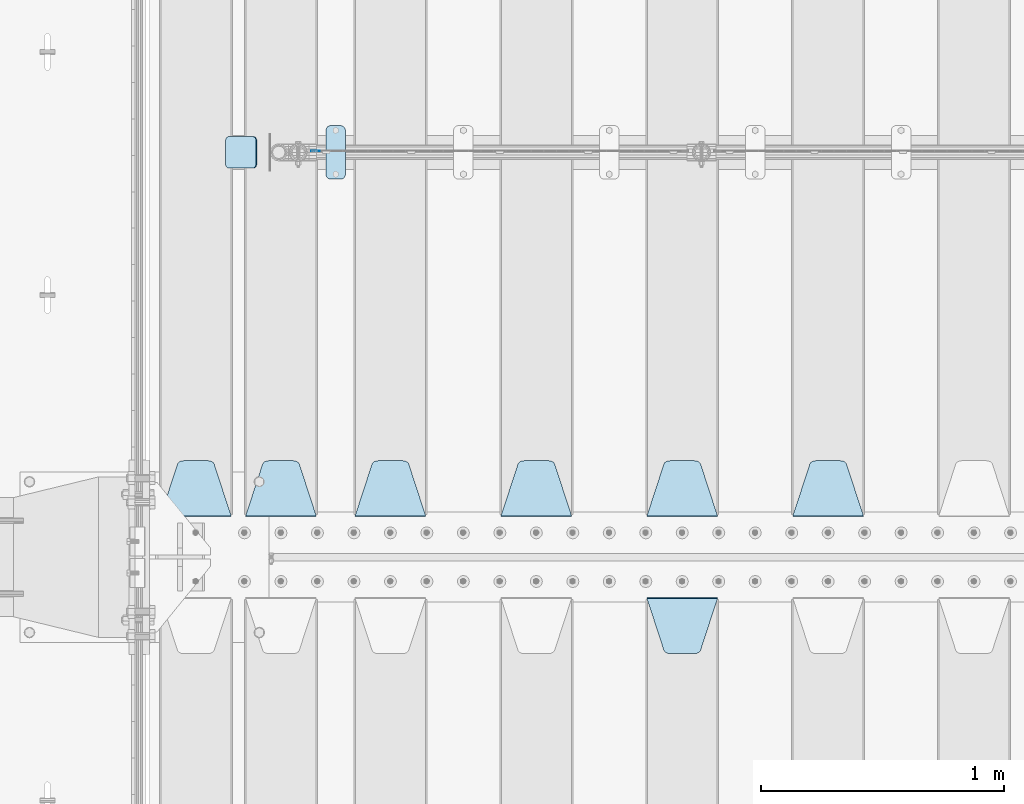
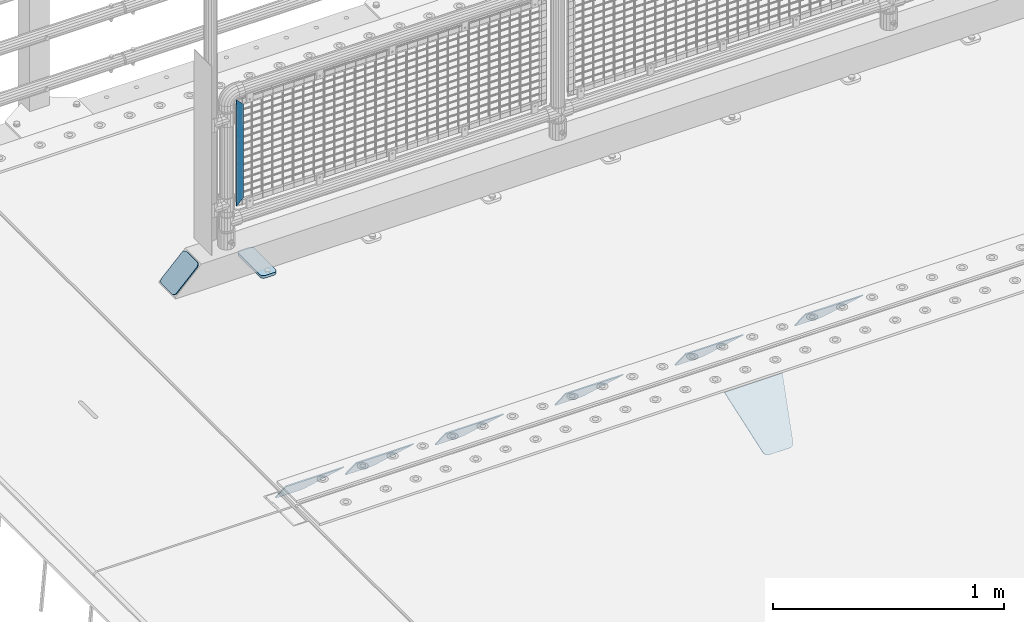
# One storey, part 210 of 240: 10 plates.
"""IFC2X3 building model written with IfcOpenShell, lengths in millimetres."""

import ifcopenshell
import ifcopenshell.guid

model = None  # the IFC model being written
_history = None  # IfcOwnerHistory: only IFC2X3 demands one
_inside = {}  # id of a spatial element -> (the spatial element, [elements in it])
_under = {}  # id of a project, library or spatial element -> (it, [spatial elements below it])
_declared = {}  # id of a project -> (the project, [libraries it declares])
_typed = {}  # id of a type object -> (the type object, [elements of that type])
_made_of = {}  # id of a material, layer set ... -> (it, [elements and type objects made of it])


def new_model(schema):
    """Start an empty IFC model of exactly this schema.

    Asked for "IFC4X3", IfcOpenShell would pick the latest addendum, in which some entities
    have other attributes; the version numbers below select the first issue.
    IFC2X3 requires an IfcOwnerHistory on every rooted entity: one is made here for all.
    """
    global model, _history
    if schema == "IFC4X3":
        model = ifcopenshell.file(schema_version=(4, 3, 0, 0))
    else:
        model = ifcopenshell.file(schema=schema)
    _inside.clear()
    _under.clear()
    _declared.clear()
    _typed.clear()
    _made_of.clear()
    _history = None
    if model.schema == "IFC2X3":
        org = make("IfcOrganization", Name="unknown")
        user = make(
            "IfcPersonAndOrganization",
            ThePerson=make("IfcPerson", FamilyName="unknown"),
            TheOrganization=org,
        )
        app = make(
            "IfcApplication",
            ApplicationDeveloper=org,
            Version="unknown",
            ApplicationFullName="unknown",
            ApplicationIdentifier="unknown",
        )
        _history = make(
            "IfcOwnerHistory",
            OwningUser=user,
            OwningApplication=app,
            ChangeAction="ADDED",
            CreationDate=0,
        )
    return model


def make(cls, **values):
    """One entity of the class cls with the attributes given. An attribute that is None is left unset."""
    return model.create_entity(
        cls, **{name: value for name, value in values.items() if value is not None}
    )


def rooted(cls, **values):
    """An entity with a GlobalId (a new one), such as an element, a storey or a relation."""
    return make(cls, GlobalId=ifcopenshell.guid.new(), OwnerHistory=_history, **values)


def si_unit(unit_type, name, prefix=None):
    """IfcSIUnit, for example si_unit("LENGTHUNIT", "METRE", prefix="MILLI")."""
    return make("IfcSIUnit", UnitType=unit_type, Prefix=prefix, Name=name)


def assignment(units):
    """IfcUnitAssignment: the units of a project."""
    return None if units is None else make("IfcUnitAssignment", Units=units)


def point(xyz):
    """IfcCartesianPoint."""
    return None if xyz is None else make("IfcCartesianPoint", Coordinates=xyz)


def direction(xyz):
    """IfcDirection."""
    return None if xyz is None else make("IfcDirection", DirectionRatios=xyz)


def frame(location, z_axis=None, x_axis=None):
    """IfcAxis2Placement3D, a coordinate frame: its origin and axes. An axis left out is left unset."""
    return make(
        "IfcAxis2Placement3D",
        Location=point(location),
        Axis=direction(z_axis),
        RefDirection=direction(x_axis),
    )


def origin_with_axes():
    """The frame at (0, 0, 0) with the z axis (0, 0, 1) and the x axis (1, 0, 0) written out."""
    return frame((0.0, 0.0, 0.0), z_axis=(0.0, 0.0, 1.0), x_axis=(1.0, 0.0, 0.0))


def place(relative_to, where):
    """IfcLocalPlacement: puts the frame where relative to a parent placement (None: the world)."""
    return make(
        "IfcLocalPlacement", PlacementRelTo=relative_to, RelativePlacement=where
    )


def context(
    kind, dimensions, precision=None, world=None, true_north=None, identifier=None
):
    """IfcGeometricRepresentationContext, for example the 3D "Model" context."""
    return make(
        "IfcGeometricRepresentationContext",
        ContextIdentifier=identifier,
        ContextType=kind,
        CoordinateSpaceDimension=dimensions,
        Precision=precision,
        WorldCoordinateSystem=world,
        TrueNorth=true_north,
    )


def subcontext(parent, identifier, kind, view, scale=None):
    """IfcGeometricRepresentationSubContext, for example "Body" below "Model"."""
    return make(
        "IfcGeometricRepresentationSubContext",
        ContextIdentifier=identifier,
        ContextType=kind,
        ParentContext=parent,
        TargetScale=scale,
        TargetView=view,
    )


def project(units=None, contexts=None):
    """IfcProject with its units and contexts."""
    return rooted(
        "IfcProject",
        Name="project",
        RepresentationContexts=contexts,
        UnitsInContext=assignment(units),
    )


def spatial(cls, under=None, at=None, **own):
    """A site, building, storey or space (cls), placed at a placement, below another one or the project."""
    s = rooted(cls, ObjectPlacement=at, **own)
    if under is not None:
        _under.setdefault(under.id(), (under, []))[1].append(s)
    return s


def faces_of(points, faces, orient=None, outer=None):
    """IfcFace entities. A face is a list of loops; a loop is a list of indices into points, from 0.

    orient and outer hold one flag for each loop. By default every Orientation is true, the
    first loop of a face is its IfcFaceOuterBound and the others are IfcFaceBound.
    """
    made = []
    for i, loops in enumerate(faces):
        bounds = []
        for j, loop in enumerate(loops):
            is_outer = j == 0 if outer is None else outer[i][j]
            bounds.append(
                make(
                    "IfcFaceOuterBound" if is_outer else "IfcFaceBound",
                    Bound=make("IfcPolyLoop", Polygon=[points[k] for k in loop]),
                    Orientation=True if orient is None else orient[i][j],
                )
            )
        made.append(make("IfcFace", Bounds=bounds))
    return made


def faceted_brep(points, faces, orient=None, outer=None, voids=None):
    """IfcFacetedBrep: a solid bounded by flat faces; with voids (closed shells), ...WithVoids."""
    shared = [point(p) for p in points]
    hull = make("IfcClosedShell", CfsFaces=faces_of(shared, faces, orient, outer))
    if voids is None:
        return make("IfcFacetedBrep", Outer=hull)
    return make(
        "IfcFacetedBrepWithVoids",
        Outer=hull,
        Voids=[
            make(cls, CfsFaces=faces_of(shared, fs, o, b)) for cls, fs, o, b in voids
        ],
    )


def shape(context_of_items, identifier, shape_type, items):
    """IfcShapeRepresentation: the items that make up one representation, for example the "Body"."""
    return make(
        "IfcShapeRepresentation",
        ContextOfItems=context_of_items,
        RepresentationIdentifier=identifier,
        RepresentationType=shape_type,
        Items=items,
    )


def material(Name=None, Category=None):
    """IfcMaterial."""
    return make("IfcMaterial", Name=Name, Category=Category)


def made_of(thing, what):
    """Note that an element or type object is made of a material, layer set ...; save() writes the relation."""
    if what is not None:
        _made_of.setdefault(what.id(), (what, []))[1].append(thing)
    return thing


def type_object(cls, material=None, **own):
    """A type object (cls), such as IfcWallType, which elements share."""
    return made_of(rooted(cls, **own), material)


def element(
    cls,
    number,
    at=None,
    inside=None,
    cuts=None,
    type_object=None,
    material=None,
    context=None,
    identifier="Body",
    shape_type=None,
    held_by="IfcProductDefinitionShape",
    body=None,
    shapes=None,
    **own,
):
    """One element of the class cls, such as IfcWall. Its Tag is "e" and its number.

    at: its placement. inside: the storey or other place that contains it. cuts: it is an
    opening in that element (IfcRelVoidsElement). A single representation is given by context,
    identifier, shape_type and body (its items); several are given by shapes. held_by: the class
    of the entity that holds the representations. save() writes the other relations.
    """
    e = rooted(cls, Tag="e%d" % number, ObjectPlacement=at, **own)
    if body is not None:
        shapes = [shape(context, identifier, shape_type, body)]
    if shapes is not None:
        e.Representation = make(held_by, Representations=shapes)
    if inside is not None:
        _inside.setdefault(inside.id(), (inside, []))[1].append(e)
    if cuts is not None:
        rooted(
            "IfcRelVoidsElement", RelatingBuildingElement=cuts, RelatedOpeningElement=e
        )
    if type_object is not None:
        _typed.setdefault(type_object.id(), (type_object, []))[1].append(e)
    return made_of(e, material)


def aggregate(whole, parts):
    """IfcRelAggregates: a whole, such as a stair, and the parts it consists of."""
    return rooted("IfcRelAggregates", RelatingObject=whole, RelatedObjects=parts)


def save(model, path):
    """Write the relations noted so far, then the file.

    IfcRelAggregates (storeys below a building ...), IfcRelContainedInSpatialStructure (elements
    in a storey), IfcRelDefinesByType, IfcRelAssociatesMaterial and IfcRelDeclares: one each for
    every whole, place, type object, material and project.
    """
    for whole, parts in _under.values():
        aggregate(whole, parts)
    for where, things in _inside.values():
        rooted(
            "IfcRelContainedInSpatialStructure",
            RelatedElements=things,
            RelatingStructure=where,
        )
    for kind, things in _typed.values():
        rooted("IfcRelDefinesByType", RelatedObjects=things, RelatingType=kind)
    for what, things in _made_of.values():
        rooted("IfcRelAssociatesMaterial", RelatedObjects=things, RelatingMaterial=what)
    for by, libraries in _declared.values():
        rooted("IfcRelDeclares", RelatingContext=by, RelatedDefinitions=libraries)
    model.write(path)


model = new_model("IFC2X3")

# Units and contexts
model_context = context("Model", 3, precision=1e-05, world=origin_with_axes())
body_context = subcontext(model_context, "Body", "Model", "MODEL_VIEW")
ifc_project = project(units=[si_unit("LENGTHUNIT", "METRE", prefix="MILLI"), si_unit("AREAUNIT", "SQUARE_METRE"), si_unit("VOLUMEUNIT", "CUBIC_METRE"), si_unit("MASSUNIT", "GRAM", prefix="KILO"), si_unit("TIMEUNIT", "SECOND"), si_unit("PLANEANGLEUNIT", "RADIAN"), si_unit("SOLIDANGLEUNIT", "STERADIAN"), si_unit("THERMODYNAMICTEMPERATUREUNIT", "DEGREE_CELSIUS"), si_unit("LUMINOUSINTENSITYUNIT", "LUMEN")], contexts=[model_context])

# Site, building, storey
site_placement = place(None, origin_with_axes())
site = spatial("IfcSite", under=ifc_project, at=site_placement, CompositionType="ELEMENT")
building_placement = place(site_placement, origin_with_axes())
building = spatial("IfcBuilding", under=site, at=building_placement, Name="Standard", CompositionType="ELEMENT")
storey_placement = place(building_placement, origin_with_axes())
storey = spatial("IfcBuildingStorey", under=building, at=storey_placement, Name="Undefined", CompositionType="ELEMENT", Elevation=0.0)

# Plates
ifc_material_1 = material(Name="STEEL/S355N")
plate_type_1 = type_object("IfcPlateType", PredefinedType="NOTDEFINED")
plate_1_placement = place(storey_placement, frame((44505.0, 32831.767766956, -1.76776695296758), z_axis=(0.0, -0.707106781186547, -0.707106781186548), x_axis=(1.0, 0.0, 0.0)))
element("IfcPlate", 1, at=plate_1_placement, inside=storey, type_object=plate_type_1, material=ifc_material_1, context=body_context, shape_type="Brep", body=[
    faceted_brep([(0.0, -2.5, 0.0), (69.345504679477, -2.50000000000364, 300.171731424827), (69.345504679477, 2.49999999999636, 300.171731424827), (0.0, 2.5, 0.0), (70.927406119954, -2.50000000000364, 304.897442415397), (70.927406119954, 2.49999999999636, 304.897442415397), (73.3818627772271, -2.50000000000728, 309.234538108525), (73.3818627772271, 2.49999999999636, 309.234538108529), (76.6187032999587, -2.50000000000728, 313.023683126099), (76.6187032999587, 2.49999999999636, 313.023683126103), (80.5190132705029, -2.50000000000364, 316.125672595368), (80.5190132705029, 2.49999999999636, 316.125672595368), (84.9395038596849, -2.50000000000364, 318.426546230472), (84.9395038596849, 2.49999999999636, 318.426546230472), (89.7177759439219, -2.5, 319.841774983277), (89.7177759439219, 2.49999999999636, 319.841774983273), (94.6782862926484, -2.50000000000364, 320.319366455074), (94.6782862926484, 2.49999999999636, 320.319366455074), (195.321713707352, -2.50000000000364, 320.319366455074), (195.321713707352, 2.49999999999636, 320.319366455074), (200.282224056078, -2.50000000000364, 319.841774983273), (200.282224056078, 2.49999999999636, 319.841774983273), (205.060496140315, -2.50000000000364, 318.426546230472), (205.060496140315, 2.49999999999636, 318.426546230472), (209.480986729497, -2.50000000000364, 316.125672595368), (209.480986729497, 2.49999999999636, 316.125672595368), (213.381296700041, -2.50000000000728, 313.023683126099), (213.381296700041, 2.49999999999272, 313.023683126099), (216.618137222766, -2.50000000000364, 309.234538108522), (216.618137222766, 2.49999999999636, 309.234538108522), (219.072593880039, -2.50000000000364, 304.897442415397), (219.072593880039, 2.49999999999636, 304.897442415397), (220.654495320523, -2.50000000000364, 300.171731424827), (220.654495320523, 2.49999999999636, 300.171731424827), (290.0, -2.50000000000364, -3.63797880709171e-12), (290.0, 2.49999999999636, -3.63797880709171e-12)], [[[0, 1, 2, 3]], [[1, 4, 5, 2]], [[4, 6, 7, 5]], [[6, 8, 9, 7]], [[8, 10, 11, 9]], [[10, 12, 13, 11]], [[12, 14, 15, 13]], [[14, 16, 17, 15]], [[16, 18, 19, 17]], [[18, 20, 21, 19]], [[20, 22, 23, 21]], [[22, 24, 25, 23]], [[24, 26, 27, 25]], [[26, 28, 29, 27]], [[28, 30, 31, 29]], [[30, 32, 33, 31]], [[32, 34, 35, 33]], [[34, 0, 3, 35]], [[5, 7, 9, 11, 13, 15, 17, 19, 21, 23, 25, 27, 29, 31, 33, 35, 3, 2]], [[34, 32, 30, 28, 26, 24, 22, 20, 18, 16, 14, 12, 10, 8, 6, 4, 1, 0]]]),
])
plate_2_placement = place(storey_placement, frame((45395.0, 33168.232233047, -1.76776695296758), z_axis=(0.0, 0.707106781186547, -0.707106781186548), x_axis=(-1.0, 0.0, 0.0)))
element("IfcPlate", 2, at=plate_2_placement, inside=storey, type_object=plate_type_1, material=ifc_material_1, context=body_context, shape_type="Brep", body=[
    faceted_brep([(0.0, -2.5, 0.0), (69.345504679477, -2.50000000000364, 300.171731424827), (69.345504679477, 2.49999999999636, 300.171731424827), (0.0, 2.5, 0.0), (70.927406119954, -2.50000000000364, 304.897442415397), (70.927406119954, 2.49999999999636, 304.897442415397), (73.3818627772271, -2.50000000000728, 309.234538108525), (73.3818627772271, 2.49999999999636, 309.234538108529), (76.6187032999587, -2.50000000000728, 313.023683126099), (76.6187032999587, 2.49999999999636, 313.023683126103), (80.5190132705029, -2.50000000000364, 316.125672595368), (80.5190132705029, 2.49999999999636, 316.125672595368), (84.9395038596849, -2.50000000000364, 318.426546230472), (84.9395038596849, 2.49999999999636, 318.426546230472), (89.7177759439219, -2.5, 319.841774983277), (89.7177759439219, 2.49999999999636, 319.841774983273), (94.6782862926484, -2.50000000000364, 320.319366455074), (94.6782862926484, 2.49999999999636, 320.319366455074), (195.321713707352, -2.50000000000364, 320.319366455074), (195.321713707352, 2.49999999999636, 320.319366455074), (200.282224056078, -2.50000000000364, 319.841774983273), (200.282224056078, 2.49999999999636, 319.841774983273), (205.060496140315, -2.50000000000364, 318.426546230472), (205.060496140315, 2.49999999999636, 318.426546230472), (209.480986729497, -2.50000000000364, 316.125672595368), (209.480986729497, 2.49999999999636, 316.125672595368), (213.381296700041, -2.50000000000728, 313.023683126099), (213.381296700041, 2.49999999999272, 313.023683126099), (216.618137222766, -2.50000000000364, 309.234538108522), (216.618137222766, 2.49999999999636, 309.234538108522), (219.072593880039, -2.50000000000364, 304.897442415397), (219.072593880039, 2.49999999999636, 304.897442415397), (220.654495320523, -2.50000000000364, 300.171731424827), (220.654495320523, 2.49999999999636, 300.171731424827), (290.0, -2.50000000000364, -3.63797880709171e-12), (290.0, 2.49999999999636, -3.63797880709171e-12)], [[[0, 1, 2, 3]], [[1, 4, 5, 2]], [[4, 6, 7, 5]], [[6, 8, 9, 7]], [[8, 10, 11, 9]], [[10, 12, 13, 11]], [[12, 14, 15, 13]], [[14, 16, 17, 15]], [[16, 18, 19, 17]], [[18, 20, 21, 19]], [[20, 22, 23, 21]], [[22, 24, 25, 23]], [[24, 26, 27, 25]], [[26, 28, 29, 27]], [[28, 30, 31, 29]], [[30, 32, 33, 31]], [[32, 34, 35, 33]], [[34, 0, 3, 35]], [[5, 7, 9, 11, 13, 15, 17, 19, 21, 23, 25, 27, 29, 31, 33, 35, 3, 2]], [[34, 32, 30, 28, 26, 24, 22, 20, 18, 16, 14, 12, 10, 8, 6, 4, 1, 0]]]),
])
plate_3_placement = place(storey_placement, frame((44795.0, 33168.232233047, -1.76776695296758), z_axis=(0.0, 0.707106781186547, -0.707106781186548), x_axis=(-1.0, 0.0, 0.0)))
element("IfcPlate", 3, at=plate_3_placement, inside=storey, type_object=plate_type_1, material=ifc_material_1, context=body_context, shape_type="Brep", body=[
    faceted_brep([(0.0, -2.5, 0.0), (69.345504679477, -2.50000000000364, 300.171731424827), (69.345504679477, 2.49999999999636, 300.171731424827), (0.0, 2.5, 0.0), (70.927406119954, -2.50000000000364, 304.897442415397), (70.927406119954, 2.49999999999636, 304.897442415397), (73.3818627772271, -2.50000000000728, 309.234538108525), (73.3818627772271, 2.49999999999636, 309.234538108529), (76.6187032999587, -2.50000000000728, 313.023683126099), (76.6187032999587, 2.49999999999636, 313.023683126103), (80.5190132705029, -2.50000000000364, 316.125672595368), (80.5190132705029, 2.49999999999636, 316.125672595368), (84.9395038596849, -2.50000000000364, 318.426546230472), (84.9395038596849, 2.49999999999636, 318.426546230472), (89.7177759439219, -2.5, 319.841774983277), (89.7177759439219, 2.49999999999636, 319.841774983273), (94.6782862926484, -2.50000000000364, 320.319366455074), (94.6782862926484, 2.49999999999636, 320.319366455074), (195.321713707352, -2.50000000000364, 320.319366455074), (195.321713707352, 2.49999999999636, 320.319366455074), (200.282224056078, -2.50000000000364, 319.841774983273), (200.282224056078, 2.49999999999636, 319.841774983273), (205.060496140315, -2.50000000000364, 318.426546230472), (205.060496140315, 2.49999999999636, 318.426546230472), (209.480986729497, -2.50000000000364, 316.125672595368), (209.480986729497, 2.49999999999636, 316.125672595368), (213.381296700041, -2.50000000000728, 313.023683126099), (213.381296700041, 2.49999999999272, 313.023683126099), (216.618137222766, -2.50000000000364, 309.234538108522), (216.618137222766, 2.49999999999636, 309.234538108522), (219.072593880039, -2.50000000000364, 304.897442415397), (219.072593880039, 2.49999999999636, 304.897442415397), (220.654495320523, -2.50000000000364, 300.171731424827), (220.654495320523, 2.49999999999636, 300.171731424827), (290.0, -2.50000000000364, -3.63797880709171e-12), (290.0, 2.49999999999636, -3.63797880709171e-12)], [[[0, 1, 2, 3]], [[1, 4, 5, 2]], [[4, 6, 7, 5]], [[6, 8, 9, 7]], [[8, 10, 11, 9]], [[10, 12, 13, 11]], [[12, 14, 15, 13]], [[14, 16, 17, 15]], [[16, 18, 19, 17]], [[18, 20, 21, 19]], [[20, 22, 23, 21]], [[22, 24, 25, 23]], [[24, 26, 27, 25]], [[26, 28, 29, 27]], [[28, 30, 31, 29]], [[30, 32, 33, 31]], [[32, 34, 35, 33]], [[34, 0, 3, 35]], [[5, 7, 9, 11, 13, 15, 17, 19, 21, 23, 25, 27, 29, 31, 33, 35, 3, 2]], [[34, 32, 30, 28, 26, 24, 22, 20, 18, 16, 14, 12, 10, 8, 6, 4, 1, 0]]]),
])
plate_4_placement = place(storey_placement, frame((44195.0, 33168.232233047, -1.76776695296758), z_axis=(0.0, 0.707106781186547, -0.707106781186548), x_axis=(-1.0, 0.0, 0.0)))
element("IfcPlate", 4, at=plate_4_placement, inside=storey, type_object=plate_type_1, material=ifc_material_1, context=body_context, shape_type="Brep", body=[
    faceted_brep([(0.0, -2.5, 0.0), (69.345504679477, -2.50000000000364, 300.171731424827), (69.345504679477, 2.49999999999636, 300.171731424827), (0.0, 2.5, 0.0), (70.927406119954, -2.50000000000364, 304.897442415397), (70.927406119954, 2.49999999999636, 304.897442415397), (73.3818627772271, -2.50000000000728, 309.234538108525), (73.3818627772271, 2.49999999999636, 309.234538108529), (76.6187032999587, -2.50000000000728, 313.023683126099), (76.6187032999587, 2.49999999999636, 313.023683126103), (80.5190132705029, -2.50000000000364, 316.125672595368), (80.5190132705029, 2.49999999999636, 316.125672595368), (84.9395038596849, -2.50000000000364, 318.426546230472), (84.9395038596849, 2.49999999999636, 318.426546230472), (89.7177759439219, -2.5, 319.841774983277), (89.7177759439219, 2.49999999999636, 319.841774983273), (94.6782862926484, -2.50000000000364, 320.319366455074), (94.6782862926484, 2.49999999999636, 320.319366455074), (195.321713707352, -2.50000000000364, 320.319366455074), (195.321713707352, 2.49999999999636, 320.319366455074), (200.282224056078, -2.50000000000364, 319.841774983273), (200.282224056078, 2.49999999999636, 319.841774983273), (205.060496140315, -2.50000000000364, 318.426546230472), (205.060496140315, 2.49999999999636, 318.426546230472), (209.480986729497, -2.50000000000364, 316.125672595368), (209.480986729497, 2.49999999999636, 316.125672595368), (213.381296700041, -2.50000000000728, 313.023683126099), (213.381296700041, 2.49999999999272, 313.023683126099), (216.618137222766, -2.50000000000364, 309.234538108522), (216.618137222766, 2.49999999999636, 309.234538108522), (219.072593880039, -2.50000000000364, 304.897442415397), (219.072593880039, 2.49999999999636, 304.897442415397), (220.654495320523, -2.50000000000364, 300.171731424827), (220.654495320523, 2.49999999999636, 300.171731424827), (290.0, -2.50000000000364, -3.63797880709171e-12), (290.0, 2.49999999999636, -3.63797880709171e-12)], [[[0, 1, 2, 3]], [[1, 4, 5, 2]], [[4, 6, 7, 5]], [[6, 8, 9, 7]], [[8, 10, 11, 9]], [[10, 12, 13, 11]], [[12, 14, 15, 13]], [[14, 16, 17, 15]], [[16, 18, 19, 17]], [[18, 20, 21, 19]], [[20, 22, 23, 21]], [[22, 24, 25, 23]], [[24, 26, 27, 25]], [[26, 28, 29, 27]], [[28, 30, 31, 29]], [[30, 32, 33, 31]], [[32, 34, 35, 33]], [[34, 0, 3, 35]], [[5, 7, 9, 11, 13, 15, 17, 19, 21, 23, 25, 27, 29, 31, 33, 35, 3, 2]], [[34, 32, 30, 28, 26, 24, 22, 20, 18, 16, 14, 12, 10, 8, 6, 4, 1, 0]]]),
])
plate_5_placement = place(storey_placement, frame((43595.0, 33168.232233047, -1.76776695296758), z_axis=(0.0, 0.707106781186547, -0.707106781186548), x_axis=(-1.0, 0.0, 0.0)))
element("IfcPlate", 5, at=plate_5_placement, inside=storey, type_object=plate_type_1, material=ifc_material_1, context=body_context, shape_type="Brep", body=[
    faceted_brep([(0.0, -2.5, 0.0), (69.345504679477, -2.50000000000364, 300.171731424827), (69.345504679477, 2.49999999999636, 300.171731424827), (0.0, 2.5, 0.0), (70.927406119954, -2.50000000000364, 304.897442415397), (70.927406119954, 2.49999999999636, 304.897442415397), (73.3818627772271, -2.50000000000728, 309.234538108525), (73.3818627772271, 2.49999999999636, 309.234538108529), (76.6187032999587, -2.50000000000728, 313.023683126099), (76.6187032999587, 2.49999999999636, 313.023683126103), (80.5190132705029, -2.50000000000364, 316.125672595368), (80.5190132705029, 2.49999999999636, 316.125672595368), (84.9395038596849, -2.50000000000364, 318.426546230472), (84.9395038596849, 2.49999999999636, 318.426546230472), (89.7177759439219, -2.5, 319.841774983277), (89.7177759439219, 2.49999999999636, 319.841774983273), (94.6782862926484, -2.50000000000364, 320.319366455074), (94.6782862926484, 2.49999999999636, 320.319366455074), (195.321713707352, -2.50000000000364, 320.319366455074), (195.321713707352, 2.49999999999636, 320.319366455074), (200.282224056078, -2.50000000000364, 319.841774983273), (200.282224056078, 2.49999999999636, 319.841774983273), (205.060496140315, -2.50000000000364, 318.426546230472), (205.060496140315, 2.49999999999636, 318.426546230472), (209.480986729497, -2.50000000000364, 316.125672595368), (209.480986729497, 2.49999999999636, 316.125672595368), (213.381296700041, -2.50000000000728, 313.023683126099), (213.381296700041, 2.49999999999272, 313.023683126099), (216.618137222766, -2.50000000000364, 309.234538108522), (216.618137222766, 2.49999999999636, 309.234538108522), (219.072593880039, -2.50000000000364, 304.897442415397), (219.072593880039, 2.49999999999636, 304.897442415397), (220.654495320523, -2.50000000000364, 300.171731424827), (220.654495320523, 2.49999999999636, 300.171731424827), (290.0, -2.50000000000364, -3.63797880709171e-12), (290.0, 2.49999999999636, -3.63797880709171e-12)], [[[0, 1, 2, 3]], [[1, 4, 5, 2]], [[4, 6, 7, 5]], [[6, 8, 9, 7]], [[8, 10, 11, 9]], [[10, 12, 13, 11]], [[12, 14, 15, 13]], [[14, 16, 17, 15]], [[16, 18, 19, 17]], [[18, 20, 21, 19]], [[20, 22, 23, 21]], [[22, 24, 25, 23]], [[24, 26, 27, 25]], [[26, 28, 29, 27]], [[28, 30, 31, 29]], [[30, 32, 33, 31]], [[32, 34, 35, 33]], [[34, 0, 3, 35]], [[5, 7, 9, 11, 13, 15, 17, 19, 21, 23, 25, 27, 29, 31, 33, 35, 3, 2]], [[34, 32, 30, 28, 26, 24, 22, 20, 18, 16, 14, 12, 10, 8, 6, 4, 1, 0]]]),
])
plate_6_placement = place(storey_placement, frame((43145.0, 33168.232233047, -1.76776695296758), z_axis=(0.0, 0.707106781186547, -0.707106781186548), x_axis=(-1.0, 0.0, 0.0)))
element("IfcPlate", 6, at=plate_6_placement, inside=storey, type_object=plate_type_1, material=ifc_material_1, context=body_context, shape_type="Brep", body=[
    faceted_brep([(0.0, -2.5, 0.0), (69.345504679477, -2.50000000000364, 300.171731424827), (69.345504679477, 2.49999999999636, 300.171731424827), (0.0, 2.5, 0.0), (70.927406119954, -2.50000000000364, 304.897442415397), (70.927406119954, 2.49999999999636, 304.897442415397), (73.3818627772271, -2.50000000000728, 309.234538108525), (73.3818627772271, 2.49999999999636, 309.234538108529), (76.6187032999587, -2.50000000000728, 313.023683126099), (76.6187032999587, 2.49999999999636, 313.023683126103), (80.5190132705029, -2.50000000000364, 316.125672595368), (80.5190132705029, 2.49999999999636, 316.125672595368), (84.9395038596849, -2.50000000000364, 318.426546230472), (84.9395038596849, 2.49999999999636, 318.426546230472), (89.7177759439219, -2.5, 319.841774983277), (89.7177759439219, 2.49999999999636, 319.841774983273), (94.6782862926484, -2.50000000000364, 320.319366455074), (94.6782862926484, 2.49999999999636, 320.319366455074), (195.321713707352, -2.50000000000364, 320.319366455074), (195.321713707352, 2.49999999999636, 320.319366455074), (200.282224056078, -2.50000000000364, 319.841774983273), (200.282224056078, 2.49999999999636, 319.841774983273), (205.060496140315, -2.50000000000364, 318.426546230472), (205.060496140315, 2.49999999999636, 318.426546230472), (209.480986729497, -2.50000000000364, 316.125672595368), (209.480986729497, 2.49999999999636, 316.125672595368), (213.381296700041, -2.50000000000728, 313.023683126099), (213.381296700041, 2.49999999999272, 313.023683126099), (216.618137222766, -2.50000000000364, 309.234538108522), (216.618137222766, 2.49999999999636, 309.234538108522), (219.072593880039, -2.50000000000364, 304.897442415397), (219.072593880039, 2.49999999999636, 304.897442415397), (220.654495320523, -2.50000000000364, 300.171731424827), (220.654495320523, 2.49999999999636, 300.171731424827), (290.0, -2.50000000000364, -3.63797880709171e-12), (290.0, 2.49999999999636, -3.63797880709171e-12)], [[[0, 1, 2, 3]], [[1, 4, 5, 2]], [[4, 6, 7, 5]], [[6, 8, 9, 7]], [[8, 10, 11, 9]], [[10, 12, 13, 11]], [[12, 14, 15, 13]], [[14, 16, 17, 15]], [[16, 18, 19, 17]], [[18, 20, 21, 19]], [[20, 22, 23, 21]], [[22, 24, 25, 23]], [[24, 26, 27, 25]], [[26, 28, 29, 27]], [[28, 30, 31, 29]], [[30, 32, 33, 31]], [[32, 34, 35, 33]], [[34, 0, 3, 35]], [[5, 7, 9, 11, 13, 15, 17, 19, 21, 23, 25, 27, 29, 31, 33, 35, 3, 2]], [[34, 32, 30, 28, 26, 24, 22, 20, 18, 16, 14, 12, 10, 8, 6, 4, 1, 0]]]),
])
plate_7_placement = place(storey_placement, frame((42795.0, 33168.232233047, -1.76776695296758), z_axis=(0.0, 0.707106781186547, -0.707106781186548), x_axis=(-1.0, 0.0, 0.0)))
element("IfcPlate", 7, at=plate_7_placement, inside=storey, type_object=plate_type_1, material=ifc_material_1, context=body_context, shape_type="Brep", body=[
    faceted_brep([(0.0, -2.5, 0.0), (69.345504679477, -2.50000000000364, 300.171731424827), (69.345504679477, 2.49999999999636, 300.171731424827), (0.0, 2.5, 0.0), (70.927406119954, -2.50000000000364, 304.897442415397), (70.927406119954, 2.49999999999636, 304.897442415397), (73.3818627772271, -2.50000000000728, 309.234538108525), (73.3818627772271, 2.49999999999636, 309.234538108529), (76.6187032999587, -2.50000000000728, 313.023683126099), (76.6187032999587, 2.49999999999636, 313.023683126103), (80.5190132705029, -2.50000000000364, 316.125672595368), (80.5190132705029, 2.49999999999636, 316.125672595368), (84.9395038596849, -2.50000000000364, 318.426546230472), (84.9395038596849, 2.49999999999636, 318.426546230472), (89.7177759439219, -2.5, 319.841774983277), (89.7177759439219, 2.49999999999636, 319.841774983273), (94.6782862926484, -2.50000000000364, 320.319366455074), (94.6782862926484, 2.49999999999636, 320.319366455074), (195.321713707352, -2.50000000000364, 320.319366455074), (195.321713707352, 2.49999999999636, 320.319366455074), (200.282224056078, -2.50000000000364, 319.841774983273), (200.282224056078, 2.49999999999636, 319.841774983273), (205.060496140315, -2.50000000000364, 318.426546230472), (205.060496140315, 2.49999999999636, 318.426546230472), (209.480986729497, -2.50000000000364, 316.125672595368), (209.480986729497, 2.49999999999636, 316.125672595368), (213.381296700041, -2.50000000000728, 313.023683126099), (213.381296700041, 2.49999999999272, 313.023683126099), (216.618137222766, -2.50000000000364, 309.234538108522), (216.618137222766, 2.49999999999636, 309.234538108522), (219.072593880039, -2.50000000000364, 304.897442415397), (219.072593880039, 2.49999999999636, 304.897442415397), (220.654495320523, -2.50000000000364, 300.171731424827), (220.654495320523, 2.49999999999636, 300.171731424827), (290.0, -2.50000000000364, -3.63797880709171e-12), (290.0, 2.49999999999636, -3.63797880709171e-12)], [[[0, 1, 2, 3]], [[1, 4, 5, 2]], [[4, 6, 7, 5]], [[6, 8, 9, 7]], [[8, 10, 11, 9]], [[10, 12, 13, 11]], [[12, 14, 15, 13]], [[14, 16, 17, 15]], [[16, 18, 19, 17]], [[18, 20, 21, 19]], [[20, 22, 23, 21]], [[22, 24, 25, 23]], [[24, 26, 27, 25]], [[26, 28, 29, 27]], [[28, 30, 31, 29]], [[30, 32, 33, 31]], [[32, 34, 35, 33]], [[34, 0, 3, 35]], [[5, 7, 9, 11, 13, 15, 17, 19, 21, 23, 25, 27, 29, 31, 33, 35, 3, 2]], [[34, 32, 30, 28, 26, 24, 22, 20, 18, 16, 14, 12, 10, 8, 6, 4, 1, 0]]]),
])
ifc_material_2 = material(Name="STEEL/S355J2")
plate_type_2 = type_object("IfcPlateType", PredefinedType="NOTDEFINED")
plate_8_placement = place(storey_placement, frame((43185.0, 34774.5, 21.0199999999977), z_axis=(1.0, 0.0, 0.0), x_axis=(0.0, -1.0, 0.0)))
element("IfcPlate", 8, at=plate_8_placement, inside=storey, type_object=plate_type_2, material=ifc_material_2, context=body_context, shape_type="Brep", body=[
    faceted_brep([(0.0, -7.0, 20.0), (0.0, -7.0, 60.0), (0.0, 7.0, 60.0), (0.0, 7.0, 20.0), (0.384294391937146, -7.0, 63.9018064403208), (0.384294391937146, 7.0, 63.9018064403208), (1.52240934977453, -7.0, 67.6536686473046), (1.52240934977453, 7.0, 67.6536686473046), (3.37060775394639, -7.0, 71.1114046603907), (3.37060775394639, 7.0, 71.1114046603907), (5.85786437626666, -7.0, 74.1421356237333), (5.85786437626666, 7.0, 74.1421356237333), (8.88859533960931, -7.0, 76.6293922460536), (8.88859533960931, 7.0, 76.6293922460536), (12.3463313526954, -7.0, 78.4775906502255), (12.3463313526954, 7.0, 78.4775906502255), (16.0981935596792, -7.0, 79.6157056080629), (16.0981935596792, 7.0, 79.6157056080629), (20.0, -7.0, 80.0), (20.0, 7.0, 80.0), (200.0, -7.0, 80.0), (200.0, 7.0, 80.0), (203.901806440321, -7.0, 79.6157056080629), (203.901806440321, 7.0, 79.6157056080629), (207.653668647305, -7.0, 78.4775906502255), (207.653668647305, 7.0, 78.4775906502255), (211.111404660391, -7.0, 76.6293922460536), (211.111404660391, 7.0, 76.6293922460536), (214.142135623733, -7.0, 74.1421356237333), (214.142135623733, 7.0, 74.1421356237333), (216.629392246054, -7.0, 71.1114046603907), (216.629392246054, 7.0, 71.1114046603907), (218.477590650225, -7.0, 67.6536686473046), (218.477590650225, 7.0, 67.6536686473046), (219.615705608063, -7.0, 63.9018064403208), (219.615705608063, 7.0, 63.9018064403208), (220.0, -7.0, 60.0), (220.0, 7.0, 60.0), (220.0, -7.0, 20.0), (220.0, 7.0, 20.0), (219.615705608063, -7.0, 16.0981935596792), (219.615705608063, 7.0, 16.0981935596792), (218.477590650225, -7.0, 12.3463313526954), (218.477590650225, 7.0, 12.3463313526954), (216.629392246054, -7.0, 8.88859533960931), (216.629392246054, 7.0, 8.88859533960931), (214.142135623733, -7.0, 5.85786437626666), (214.142135623733, 7.0, 5.85786437626666), (211.111404660391, -7.0, 3.37060775394639), (211.111404660391, 7.0, 3.37060775394639), (207.653668647305, -7.0, 1.52240934977453), (207.653668647305, 7.0, 1.52240934977453), (203.901806440321, -7.0, 0.384294391937146), (203.901806440321, 7.0, 0.384294391937146), (200.0, -7.0, 0.0), (200.0, 7.0, 0.0), (20.0, -7.0, 0.0), (20.0, 7.0, 0.0), (16.0981935596792, -7.0, 0.384294391937146), (16.0981935596792, 7.0, 0.384294391937146), (12.3463313526954, -7.0, 1.52240934977453), (12.3463313526954, 7.0, 1.52240934977453), (8.88859533960931, -7.0, 3.37060775394639), (8.88859533960931, 7.0, 3.37060775394639), (5.85786437626666, -7.0, 5.85786437626666), (5.85786437626666, 7.0, 5.85786437626666), (3.37060775394639, -7.0, 8.88859533960931), (3.37060775394639, 7.0, 8.88859533960931), (1.52240934977453, -7.0, 12.3463313526954), (1.52240934977453, 7.0, 12.3463313526954), (0.384294391937146, -7.0, 16.0981935596792), (0.384294391937146, 7.0, 16.0981935596792)], [[[0, 1, 2, 3]], [[1, 4, 5, 2]], [[4, 6, 7, 5]], [[6, 8, 9, 7]], [[8, 10, 11, 9]], [[10, 12, 13, 11]], [[12, 14, 15, 13]], [[14, 16, 17, 15]], [[16, 18, 19, 17]], [[18, 20, 21, 19]], [[20, 22, 23, 21]], [[22, 24, 25, 23]], [[24, 26, 27, 25]], [[26, 28, 29, 27]], [[28, 30, 31, 29]], [[30, 32, 33, 31]], [[32, 34, 35, 33]], [[34, 36, 37, 35]], [[36, 38, 39, 37]], [[38, 40, 41, 39]], [[40, 42, 43, 41]], [[42, 44, 45, 43]], [[44, 46, 47, 45]], [[46, 48, 49, 47]], [[48, 50, 51, 49]], [[50, 52, 53, 51]], [[52, 54, 55, 53]], [[54, 56, 57, 55]], [[56, 58, 59, 57]], [[58, 60, 61, 59]], [[60, 62, 63, 61]], [[62, 64, 65, 63]], [[64, 66, 67, 65]], [[66, 68, 69, 67]], [[68, 70, 71, 69]], [[70, 0, 3, 71]], [[5, 7, 9, 11, 13, 15, 17, 19, 21, 23, 25, 27, 29, 31, 33, 35, 37, 39, 41, 43, 45, 47, 49, 51, 53, 55, 57, 59, 61, 63, 65, 67, 69, 71, 3, 2]], [[70, 68, 66, 64, 62, 60, 58, 56, 54, 52, 50, 48, 46, 44, 42, 40, 38, 36, 34, 32, 30, 28, 26, 24, 22, 20, 18, 16, 14, 12, 10, 8, 6, 4, 1, 0]]]),
])
plate_type_3 = type_object("IfcPlateType", PredefinedType="NOTDEFINED")
plate_9_placement = place(storey_placement, frame((42899.807581521, 34729.5, 166.254400376559), z_axis=(-0.707410512925779, 0.0, -0.70680291892584), x_axis=(0.0, -1.0, 0.0)))
element("IfcPlate", 9, at=plate_9_placement, inside=storey, type_object=plate_type_3, material=ifc_material_2, context=body_context, shape_type="Brep", body=[
    faceted_brep([(0.0, -2.5, 20.0), (0.0, -2.5, 158.926651000977), (0.0, 2.50000000000728, 158.926651000969), (0.0, 2.5, 19.9999999999927), (0.384294391937146, -2.50000000000728, 162.828457441297), (0.384294391937146, 2.5, 162.828457441297), (1.52240934977453, -2.5, 166.580319648274), (1.52240934977453, 2.50000000000728, 166.580319648274), (3.37060775394639, -2.5, 170.038055661367), (3.37060775394639, 2.5, 170.038055661367), (5.85786437626666, -2.49999999999272, 173.068786624703), (5.85786437626666, 2.5, 173.068786624703), (8.88859533960931, -2.5, 175.556043247023), (8.88859533960931, 2.50000000000728, 175.556043247023), (12.3463313526954, -2.5, 177.404241651195), (12.3463313526954, 2.50000000000728, 177.404241651195), (16.0981935596792, -2.5, 178.542356609039), (16.0981935596792, 2.50000000000728, 178.542356609039), (20.0, -2.5, 178.926651000977), (20.0, 2.5, 178.926651000977), (110.0, -2.5, 178.926651000977), (110.0, 2.5, 178.926651000977), (113.901806440321, -2.5, 178.542356609039), (113.901806440321, 2.50000000000728, 178.542356609039), (117.653668647305, -2.5, 177.404241651195), (117.653668647305, 2.50000000000728, 177.404241651195), (121.111404660391, -2.5, 175.556043247023), (121.111404660391, 2.50000000000728, 175.556043247023), (124.142135623733, -2.49999999999272, 173.068786624703), (124.142135623733, 2.5, 173.068786624703), (126.629392246054, -2.5, 170.038055661367), (126.629392246054, 2.5, 170.038055661367), (128.477590650225, -2.5, 166.580319648274), (128.477590650225, 2.50000000000728, 166.580319648274), (129.615705608063, -2.50000000000728, 162.828457441297), (129.615705608063, 2.5, 162.828457441297), (130.0, -2.5, 158.926651000977), (130.0, 2.50000000000728, 158.926651000969), (130.0, -2.5, 20.0), (130.0, 2.5, 19.9999999999927), (129.615705608063, -2.5, 16.0981935596719), (129.615705608063, 2.50000000000728, 16.0981935596719), (128.477590650225, -2.50000000000728, 12.3463313527027), (128.477590650225, 2.5, 12.3463313526954), (126.629392246054, -2.49999999999272, 8.88859533960931), (126.629392246054, 2.5, 8.88859533960931), (124.142135623733, -2.49999999999272, 5.85786437626666), (124.142135623733, 2.5, 5.85786437626666), (121.111404660391, -2.5, 3.37060775394639), (121.111404660391, 2.5, 3.37060775393911), (117.653668647305, -2.5, 1.52240934976726), (117.653668647305, 2.5, 1.52240934977453), (113.901806440321, -2.5, 0.38429439192987), (113.901806440321, 2.5, 0.38429439192987), (110.0, -2.5, 0.0), (110.0, 2.5, 0.0), (20.0, -2.5, 0.0), (20.0, 2.5, 0.0), (16.0981935596792, -2.5, 0.38429439192987), (16.0981935596792, 2.5, 0.38429439192987), (12.3463313526954, -2.5, 1.52240934976726), (12.3463313526954, 2.5, 1.52240934977453), (8.88859533960931, -2.5, 3.37060775394639), (8.88859533960931, 2.5, 3.37060775393911), (5.85786437626666, -2.49999999999272, 5.85786437626666), (5.85786437626666, 2.5, 5.85786437626666), (3.37060775394639, -2.49999999999272, 8.88859533960931), (3.37060775394639, 2.5, 8.88859533960931), (1.52240934977453, -2.5, 12.3463313526954), (1.52240934977453, 2.5, 12.3463313526954), (0.384294391937146, -2.5, 16.0981935596719), (0.384294391937146, 2.50000000000728, 16.0981935596719)], [[[0, 1, 2, 3]], [[1, 4, 5, 2]], [[4, 6, 7, 5]], [[6, 8, 9, 7]], [[8, 10, 11, 9]], [[10, 12, 13, 11]], [[12, 14, 15, 13]], [[14, 16, 17, 15]], [[16, 18, 19, 17]], [[18, 20, 21, 19]], [[20, 22, 23, 21]], [[22, 24, 25, 23]], [[24, 26, 27, 25]], [[26, 28, 29, 27]], [[28, 30, 31, 29]], [[30, 32, 33, 31]], [[32, 34, 35, 33]], [[34, 36, 37, 35]], [[36, 38, 39, 37]], [[38, 40, 41, 39]], [[40, 42, 43, 41]], [[42, 44, 45, 43]], [[44, 46, 47, 45]], [[46, 48, 49, 47]], [[48, 50, 51, 49]], [[50, 52, 53, 51]], [[52, 54, 55, 53]], [[54, 56, 57, 55]], [[56, 58, 59, 57]], [[58, 60, 61, 59]], [[60, 62, 63, 61]], [[62, 64, 65, 63]], [[64, 66, 67, 65]], [[66, 68, 69, 67]], [[68, 70, 71, 69]], [[70, 0, 3, 71]], [[5, 7, 9, 11, 13, 15, 17, 19, 21, 23, 25, 27, 29, 31, 33, 35, 37, 39, 41, 43, 45, 47, 49, 51, 53, 55, 57, 59, 61, 63, 65, 67, 69, 71, 3, 2]], [[70, 68, 66, 64, 62, 60, 58, 56, 54, 52, 50, 48, 46, 44, 42, 40, 38, 36, 34, 32, 30, 28, 26, 24, 22, 20, 18, 16, 14, 12, 10, 8, 6, 4, 1, 0]]]),
])
ifc_material_3 = material(Name="Misc_Undefined")
plate_type_4 = type_object("IfcPlateType", PredefinedType="NOTDEFINED")
plate_10_placement = place(storey_placement, frame((43159.509713541, 34670.5, 879.519963133601), z_axis=(-0.707008801899317, 0.0, -0.707204746899292), x_axis=(-0.707204746899293, 0.0, 0.707008801899317)))
element("IfcPlate", 10, at=plate_10_placement, inside=storey, type_object=plate_type_4, material=ifc_material_3, context=body_context, shape_type="Brep", body=[
    faceted_brep([(-7.27595761418343e-12, -1.49999999999272, 0.0), (-348.552185058594, -1.5, 348.65502929686), (-348.552185058594, 1.5, 348.65502929686), (0.0, 1.50000000000728, 0.0), (-348.544891357415, -1.5, 398.152496337883), (-348.544891357415, 1.5, 398.152496337883), (49.5043945312573, -1.5, 6.54836185276508e-11), (49.5043945312573, 1.5, 6.54836185276508e-11)], [[[0, 1, 2, 3]], [[1, 4, 5, 2]], [[4, 6, 7, 5]], [[6, 0, 3, 7]], [[5, 7, 3, 2]], [[6, 4, 1, 0]]]),
])

save(model, "model.ifc")
